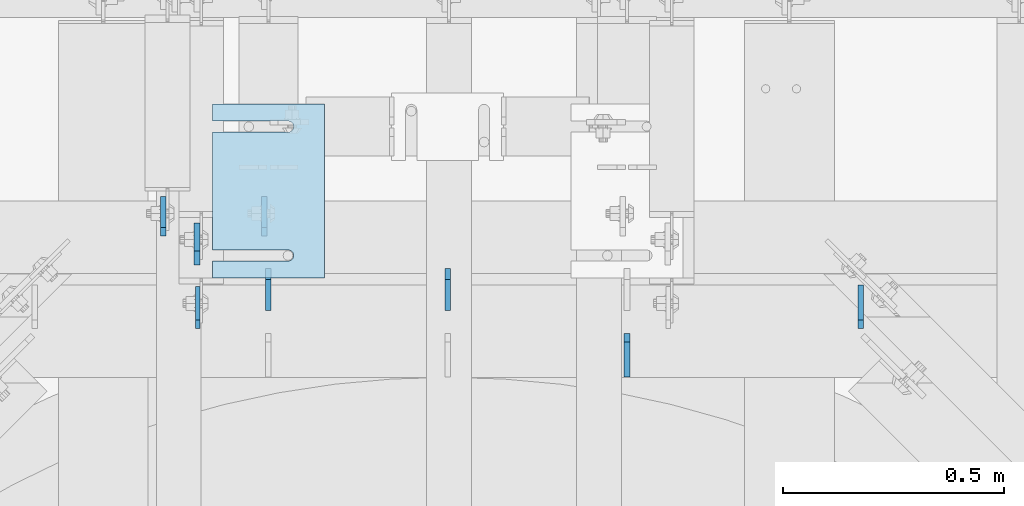
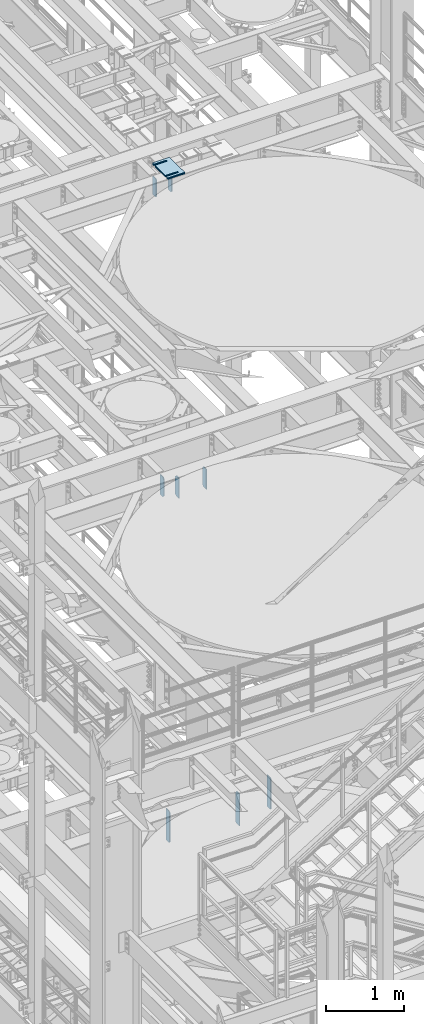
# One storey, part 1574 of 1876: 14 plates, 9 elements without a shape of their own.
"""IFC2X3 building model written with IfcOpenShell, lengths in millimetres."""

from ifc_helpers import new_model, si_unit, frame, origin_with_axes, place, context, subcontext, project, spatial, faceted_brep, material, type_object, element, aggregate, save


model = new_model("IFC2X3")

# Units and contexts
model_context = context("Model", 3, precision=1e-05, world=origin_with_axes())
body_context = subcontext(model_context, "Body", "Model", "MODEL_VIEW")
ifc_project = project(units=[si_unit("LENGTHUNIT", "METRE", prefix="MILLI"), si_unit("AREAUNIT", "SQUARE_METRE"), si_unit("VOLUMEUNIT", "CUBIC_METRE"), si_unit("MASSUNIT", "GRAM", prefix="KILO"), si_unit("TIMEUNIT", "SECOND"), si_unit("PLANEANGLEUNIT", "RADIAN"), si_unit("SOLIDANGLEUNIT", "STERADIAN"), si_unit("THERMODYNAMICTEMPERATUREUNIT", "DEGREE_CELSIUS"), si_unit("LUMINOUSINTENSITYUNIT", "LUMEN")], contexts=[model_context])

# Site, building, storey
site_placement = place(None, origin_with_axes())
site = spatial("IfcSite", under=ifc_project, at=site_placement, CompositionType="ELEMENT")
building_placement = place(site_placement, origin_with_axes())
building = spatial("IfcBuilding", under=site, at=building_placement, Name="Undefined", CompositionType="ELEMENT")
storey_placement = place(building_placement, origin_with_axes())
storey = spatial("IfcBuildingStorey", under=building, at=storey_placement, Name="Undefined", CompositionType="ELEMENT", Elevation=0.0)

# Assembly, plates
assembly_1_placement = place(storey_placement, origin_with_axes())
assembly_1 = element("IfcElementAssembly", 1, at=assembly_1_placement, inside=storey, Name="BEAM", AssemblyPlace="NOTDEFINED", PredefinedType="RIGID_FRAME")
ifc_material = material(Name="STEEL/A36")
plate_type_1 = type_object("IfcPlateType", PredefinedType="NOTDEFINED")
plate_1_placement = place(assembly_1_placement, frame((3852.86200008392, 704.254688, 7635.875), z_axis=(0.0, 0.0, 1.0), x_axis=(0.0, 1.0, 0.0)))
plate_1 = element("IfcPlate", 2, at=plate_1_placement, type_object=plate_type_1, material=ifc_material, Name="PLATE", context=body_context, shape_type="Brep", body=[
    faceted_brep([(0.0, -4.76249999999982, 19.0499992370605), (0.0, -4.76249999999982, 481.012500762939), (0.0, 4.76249999999982, 481.012500762939), (0.0, 4.76249999999982, 19.0499992370605), (19.0499992370605, -4.76249999999982, 500.0625), (19.0499992370605, 4.76249999999982, 500.0625), (95.25, -4.76249999999982, 500.0625), (95.25, 4.76249999999982, 500.0625), (95.25, -4.76249999999982, 0.0), (95.25, 4.76249999999982, 0.0), (19.0499992370605, -4.76249999999982, 0.0), (19.0499992370605, 4.76249999999982, 0.0)], [[[0, 1, 2, 3]], [[1, 4, 5, 2]], [[4, 6, 7, 5]], [[6, 8, 9, 7]], [[8, 10, 11, 9]], [[10, 0, 3, 11]], [[5, 7, 9, 11, 3, 2]], [[10, 8, 6, 4, 1, 0]]]),
])
plate_type_2 = type_object("IfcPlateType", PredefinedType="NOTDEFINED")
plate_2_placement = place(assembly_1_placement, frame((4825.99999998806, 594.717188, 7634.2875), z_axis=(0.0, 0.0, 1.0), x_axis=(0.0, 1.0, 0.0)))
plate_2 = element("IfcPlate", 3, at=plate_2_placement, type_object=plate_type_2, material=ifc_material, Name="PLATE", context=body_context, shape_type="Brep", body=[
    faceted_brep([(0.0, -6.35000000000036, 0.0), (0.0, -6.34999999999991, 501.649993896484), (0.0, 6.34999999999991, 501.649993896484), (0.0, 6.35000000000036, 0.0), (79.3750038146973, -6.34999999999991, 501.649993896484), (79.3750038146973, 6.34999999999991, 501.649993896484), (98.4250030517578, -6.34999999999991, 476.249994277954), (98.4250030517578, 6.34999999999991, 476.249994277954), (98.4250030517578, -6.34999999999991, 19.0499992370605), (98.4250030517578, 6.34999999999991, 19.0499992370605), (79.3750038146973, -6.34999999999991, 0.0), (79.3750038146973, 6.34999999999991, 0.0)], [[[0, 1, 2, 3]], [[1, 4, 5, 2]], [[4, 6, 7, 5]], [[6, 8, 9, 7]], [[8, 10, 11, 9]], [[10, 0, 3, 11]], [[5, 7, 9, 11, 3, 2]], [[10, 8, 6, 4, 1, 0]]]),
])

assembly_2_placement = place(storey_placement, origin_with_axes())
assembly_2 = element("IfcElementAssembly", 4, at=assembly_2_placement, inside=storey, Name="BEAM", AssemblyPlace="NOTDEFINED", PredefinedType="RIGID_FRAME")
plate_type_3 = type_object("IfcPlateType", PredefinedType="NOTDEFINED")
plate_3_placement = place(assembly_2_placement, frame((4003.67517775661, 914.399999999455, 17681.575), z_axis=(0.0, 0.0, 1.0), x_axis=(0.0, 1.0, 0.0)))
plate_3 = element("IfcPlate", 5, at=plate_3_placement, type_object=plate_type_3, material=ifc_material, Name="PLATE", context=body_context, shape_type="Brep", body=[
    faceted_brep([(0.0, -6.35000000000196, 19.0499992370605), (0.0, -6.35000000000036, 271.462512969971), (0.0, 6.35000000000036, 271.462512969971), (0.0, 6.35000000000105, 19.0499992370605), (19.0499992370605, -6.35000000000036, 290.512512207031), (19.0499992370605, 6.35000000000036, 290.512512207031), (88.9000015258789, -6.35000000000036, 290.512512207031), (88.9000015258789, 6.35000000000036, 290.512512207031), (88.9000015258789, -6.34999999999991, 0.0), (88.9000015258789, 6.34999999999991, 0.0), (19.0499992370642, -6.35000000000105, 0.0), (19.0499992370633, 6.35000000000105, 0.0)], [[[0, 1, 2, 3]], [[1, 4, 5, 2]], [[4, 6, 7, 5]], [[6, 8, 9, 7]], [[8, 10, 11, 9]], [[10, 0, 3, 11]], [[5, 7, 9, 11, 3, 2]], [[10, 8, 6, 4, 1, 0]]]),
])
plate_4_placement = place(assembly_2_placement, frame((3775.07499990463, 914.399999999455, 17679.9875), z_axis=(0.0, 0.0, 1.0), x_axis=(0.0, 1.0, 0.0)))
plate_4 = element("IfcPlate", 6, at=plate_4_placement, type_object=plate_type_3, material=ifc_material, Name="PLATE", context=body_context, shape_type="Brep", body=[
    faceted_brep([(0.0, -6.35000000000196, 19.0499992370605), (9.09494701772928e-13, -6.34999999999832, 273.050006866455), (-2.72848410531878e-12, 6.34999999999923, 273.050006866455), (0.0, 6.35000000000105, 19.0499992370605), (19.0499992370578, -6.35000000000696, 292.100006103516), (19.049999237056, 6.3499999999915, 292.100006103516), (88.9000015258789, -6.35000000000036, 292.100006103516), (88.9000015258789, 6.35000000000036, 292.100006103516), (88.9000015258789, -6.34999999999991, 0.0), (88.9000015258789, 6.34999999999991, 0.0), (19.0499992370642, -6.35000000000105, 0.0), (19.0499992370633, 6.35000000000105, 0.0)], [[[0, 1, 2, 3]], [[1, 4, 5, 2]], [[4, 6, 7, 5]], [[6, 8, 9, 7]], [[8, 10, 11, 9]], [[10, 0, 3, 11]], [[5, 7, 9, 11, 3, 2]], [[10, 8, 6, 4, 1, 0]]]),
])
aggregate(assembly_2, [plate_3, plate_4])

assembly_3_placement = place(storey_placement, origin_with_axes())
assembly_3 = element("IfcElementAssembly", 7, at=assembly_3_placement, inside=storey, Name="BEAM", AssemblyPlace="NOTDEFINED", PredefinedType="RIGID_FRAME")
plate_type_4 = type_object("IfcPlateType", PredefinedType="NOTDEFINED")
plate_5_placement = place(assembly_3_placement, frame((4013.2, 745.33125, 12976.225), z_axis=(0.0, 0.0, 1.0), x_axis=(0.0, 1.0, 0.0)))
plate_5 = element("IfcPlate", 8, at=plate_5_placement, type_object=plate_type_4, material=ifc_material, Name="PLATE", context=body_context, shape_type="Brep", body=[
    faceted_brep([(0.0, -6.35000000000036, 0.0), (1.81898940354586e-12, -6.35000000000127, 317.5), (0.0, 6.35000000000036, 317.5), (0.0, 6.35000000000036, 0.0), (69.8500003814697, -6.34999999999991, 317.5), (69.8500003814697, 6.34999999999991, 317.5), (95.25, -6.34999999999991, 292.10000038147), (95.25, 6.34999999999991, 292.10000038147), (95.25, -6.34999999999991, 25.3999996185303), (95.25, 6.34999999999991, 25.3999996185303), (69.8500003814697, -6.34999999999991, 0.0), (69.8500003814697, 6.34999999999991, 0.0)], [[[0, 1, 2, 3]], [[1, 4, 5, 2]], [[4, 6, 7, 5]], [[6, 8, 9, 7]], [[8, 10, 11, 9]], [[10, 0, 3, 11]], [[5, 7, 9, 11, 3, 2]], [[10, 8, 6, 4, 1, 0]]]),
])
plate_6_placement = place(assembly_3_placement, frame((4419.6, 745.33125, 12976.225), z_axis=(0.0, 0.0, 1.0), x_axis=(0.0, 1.0, 0.0)))
plate_6 = element("IfcPlate", 9, at=plate_6_placement, type_object=plate_type_4, material=ifc_material, Name="PLATE", context=body_context, shape_type="Brep", body=[
    faceted_brep([(0.0, -6.35000000000036, 0.0), (1.81898940354586e-12, -6.35000000000127, 317.5), (0.0, 6.35000000000036, 317.5), (0.0, 6.35000000000036, 0.0), (69.8500003814697, -6.34999999999991, 317.5), (69.8500003814697, 6.34999999999991, 317.5), (95.25, -6.34999999999991, 292.10000038147), (95.25, 6.34999999999991, 292.10000038147), (95.25, -6.34999999999991, 25.3999996185303), (95.25, 6.34999999999991, 25.3999996185303), (69.8500003814697, -6.34999999999991, 0.0), (69.8500003814697, 6.34999999999991, 0.0)], [[[0, 1, 2, 3]], [[1, 4, 5, 2]], [[4, 6, 7, 5]], [[6, 8, 9, 7]], [[8, 10, 11, 9]], [[10, 0, 3, 11]], [[5, 7, 9, 11, 3, 2]], [[10, 8, 6, 4, 1, 0]]]),
])
plate_7_placement = place(assembly_3_placement, frame((3851.27499990463, 848.51875, 12977.8125), z_axis=(0.0, 0.0, 1.0), x_axis=(0.0, 1.0, 0.0)))
plate_7 = element("IfcPlate", 10, at=plate_7_placement, type_object=plate_type_4, material=ifc_material, Name="PLATE", context=body_context, shape_type="Brep", body=[
    faceted_brep([(0.0, -6.34999999999991, 31.75), (-1.81898940354586e-12, -6.34999999999991, 284.162506103516), (1.81898940354586e-12, 6.35000000000173, 284.162506103516), (0.0, 6.34999999999991, 31.75), (31.7499999999927, -6.34999999999991, 315.912506103516), (31.7499999999982, 6.35000000000309, 315.912506103516), (95.25, -6.35000000000036, 315.912506103516), (95.25, 6.35000000000036, 315.912506103516), (95.25, -6.35000000000036, 0.0), (95.25, 6.35000000000036, 0.0), (31.75, -6.34999999999991, 0.0), (31.75, 6.34999999999991, 0.0)], [[[0, 1, 2, 3]], [[1, 4, 5, 2]], [[4, 6, 7, 5]], [[6, 8, 9, 7]], [[8, 10, 11, 9]], [[10, 0, 3, 11]], [[5, 7, 9, 11, 3, 2]], [[10, 8, 6, 4, 1, 0]]]),
])
aggregate(assembly_3, [plate_5, plate_6, plate_7])

# Plate
plate_type_5 = type_object("IfcPlateType", PredefinedType="NOTDEFINED")
plate_8_placement = place(assembly_1_placement, frame((5355.59998036883, 704.254688, 7635.875), z_axis=(0.0, 0.0, 1.0), x_axis=(0.0, 1.0, 0.0)))
plate_8 = element("IfcPlate", 11, at=plate_8_placement, type_object=plate_type_5, material=ifc_material, Name="PLATE", context=body_context, shape_type="Brep", body=[
    faceted_brep([(0.0, -6.35000000000196, 19.0499992370605), (0.0, -6.34999999999991, 479.425006866455), (0.0, 6.34999999999991, 479.425006866455), (0.0, 6.35000000000105, 19.0499992370605), (19.0499992370605, -6.34999999999991, 498.475006103516), (19.0499992370605, 6.34999999999991, 498.475006103516), (99.21875, -6.34999999999991, 498.475006103516), (99.21875, 6.34999999999991, 498.475006103516), (99.21875, -6.34999999999991, 0.0), (99.21875, 6.34999999999991, 0.0), (19.0499992370642, -6.35000000000105, 0.0), (19.0499992370633, 6.35000000000105, 0.0)], [[[0, 1, 2, 3]], [[1, 4, 5, 2]], [[4, 6, 7, 5]], [[6, 8, 9, 7]], [[8, 10, 11, 9]], [[10, 0, 3, 11]], [[5, 7, 9, 11, 3, 2]], [[10, 8, 6, 4, 1, 0]]]),
])

aggregate(assembly_1, [plate_2, plate_8, plate_1])

# Assembly, plate
assembly_4_placement = place(storey_placement, origin_with_axes())
assembly_4 = element("IfcElementAssembly", 12, at=assembly_4_placement, inside=storey, Name="SHIM PLATE", AssemblyPlace="NOTDEFINED", PredefinedType="RIGID_FRAME")
plate_type_6 = type_object("IfcPlateType", PredefinedType="NOTDEFINED")
plate_9_placement = place(assembly_4_placement, frame((4140.19755067496, 819.151560067776, 18007.0115), z_axis=(-1.0, 0.0, 0.0), x_axis=(0.0, 1.0, 0.0)))
plate_9 = element("IfcPlate", 13, at=plate_9_placement, type_object=plate_type_6, material=ifc_material, Name="SHIM PLATE", context=body_context, shape_type="Brep", body=[
    faceted_brep([(38.0954210666328, -1.58750000000146, 253.999557495103), (38.0976431969724, -1.58750000000146, 82.6182312417654), (38.0976431969724, 1.58750000000146, 82.6182312417654), (38.0954210666328, 1.58750000000146, 253.999557495103), (39.7991131045027, -1.58750000000146, 76.2682279470096), (39.7991131045027, 1.58750000000146, 76.2682279470096), (44.4476316136985, -1.58750000000146, 71.6196994315187), (44.4476316136985, 1.58750000000146, 71.6196994315187), (50.7976312458977, -1.58750000000146, 69.9182158551362), (50.7976312458977, 1.58750000000146, 69.9182158551362), (57.1476337740625, -1.58750000000146, 71.6196886236189), (57.1476337740625, 1.58750000000146, 71.6196886236189), (61.7961601951824, -1.58750000000146, 76.2682092271793), (61.7961601951824, 1.58750000000146, 76.2682092271793), (63.497640910601, -1.58750000000146, 82.6182096259718), (63.497640910601, 1.58750000000146, 82.6182096259718), (63.4954187799489, -1.58750000000146, 253.999557267866), (63.4954187799489, 1.58750000000146, 253.999557495093), (9.09494701772928e-13, -1.58750000000146, 4.54747350886464e-13), (1.89071320164658e-05, -1.58750000000146, 253.999557495117), (1.89071320164658e-05, 1.58750000000146, 253.999557495117), (9.09494701772928e-13, 1.58750000000146, 4.54747350886464e-13), (393.698486328125, -1.58750000000146, -1.40062184073031e-10), (393.698486328125, 1.58750000000146, -1.40062184073031e-10), (393.698516845714, -1.58750000000146, 253.999557494967), (393.698516845714, 1.58750000000146, 253.999557494967), (355.593905292273, 1.58750000000146, 253.999557494981), (355.593905292273, -1.58750000000146, 253.999558194833), (355.596127251301, 1.58750000000146, 82.6182258117283), (355.596127251301, -1.58750000000146, 82.6182258117283), (353.894652887411, 1.58750000000146, 76.2682211679371), (353.894652887411, -1.58750000000146, 76.2682211679371), (349.246128913514, 1.58750000000146, 71.6196946431969), (349.246128913514, -1.58750000000146, 71.6196946431969), (342.896125203397, 1.58750000000146, 69.9182167947934), (342.896125203397, -1.58750000000146, 69.9182167947934), (336.546122348359, 1.58750000000146, 71.6196978343955), (336.546122348359, -1.58750000000146, 71.6196978343955), (331.897600710579, 1.58750000000146, 76.2682266952543), (331.897600710579, -1.58750000000146, 76.2682266952543), (330.196129537885, 1.58750000000146, 82.6182321941214), (330.196129537885, -1.58750000000146, 82.6182321941214), (330.193907578964, -1.58750000000146, 253.999557494991), (330.193907578964, 1.58750000000146, 253.999557494991)], [[[0, 1, 2, 3]], [[4, 5, 2, 1]], [[6, 7, 5, 4]], [[8, 9, 7, 6]], [[10, 11, 9, 8]], [[12, 13, 11, 10]], [[14, 15, 13, 12]], [[16, 17, 15, 14]], [[18, 19, 20, 21]], [[22, 18, 21, 23]], [[24, 22, 23, 25]], [[24, 25, 26, 27]], [[27, 26, 28, 29]], [[29, 28, 30, 31]], [[31, 30, 32, 33]], [[33, 32, 34, 35]], [[35, 34, 36, 37]], [[37, 36, 38, 39]], [[39, 38, 40, 41]], [[42, 41, 40, 43]], [[12, 10, 8, 6, 4, 1, 0, 19, 18, 22, 24, 27, 29, 31, 33, 35, 37, 39, 41, 42, 16, 14]], [[20, 19, 0, 3]], [[43, 40, 38, 36, 34, 32, 30, 28, 26, 25, 23, 21, 20, 3, 2, 5, 7, 9, 11, 13, 15, 17]], [[42, 43, 17, 16]]]),
])
aggregate(assembly_4, [plate_9])

assembly_5_placement = place(storey_placement, origin_with_axes())
assembly_5 = element("IfcElementAssembly", 14, at=assembly_5_placement, inside=storey, Name="SHIM PLATE", AssemblyPlace="NOTDEFINED", PredefinedType="RIGID_FRAME")
plate_10_placement = place(assembly_5_placement, frame((4140.19755067514, 819.151560067778, 18003.8365), z_axis=(-1.0, 0.0, 0.0), x_axis=(0.0, 1.0, 0.0)))
plate_10 = element("IfcPlate", 15, at=plate_10_placement, type_object=plate_type_6, material=ifc_material, Name="SHIM PLATE", context=body_context, shape_type="Brep", body=[
    faceted_brep([(38.0954210666328, -1.58750000000146, 253.999557495103), (38.0976431969724, -1.58750000000146, 82.6182312417654), (38.0976431969724, 1.58750000000146, 82.6182312417654), (38.0954210666328, 1.58750000000146, 253.999557495103), (39.7991131045027, -1.58750000000146, 76.2682279470096), (39.7991131045027, 1.58750000000146, 76.2682279470096), (44.4476316136985, -1.58750000000146, 71.6196994315187), (44.4476316136985, 1.58750000000146, 71.6196994315187), (50.7976312458977, -1.58750000000146, 69.9182158551362), (50.7976312458977, 1.58750000000146, 69.9182158551362), (57.1476337740625, -1.58750000000146, 71.6196886236189), (57.1476337740625, 1.58750000000146, 71.6196886236189), (61.7961601951824, -1.58750000000146, 76.2682092271793), (61.7961601951824, 1.58750000000146, 76.2682092271793), (63.497640910601, -1.58750000000146, 82.6182096259718), (63.497640910601, 1.58750000000146, 82.6182096259718), (63.4954187799489, -1.58750000000146, 253.999557267866), (63.4954187799489, 1.58750000000146, 253.999557495093), (9.09494701772928e-13, -1.58750000000146, 4.54747350886464e-13), (1.89071320164658e-05, -1.58750000000146, 253.999557495117), (1.89071320164658e-05, 1.58750000000146, 253.999557495117), (9.09494701772928e-13, 1.58750000000146, 4.54747350886464e-13), (393.698486328125, -1.58750000000146, -1.40062184073031e-10), (393.698486328125, 1.58750000000146, -1.40062184073031e-10), (393.698516845714, -1.58750000000146, 253.999557494967), (393.698516845714, 1.58750000000146, 253.999557494967), (355.593905292273, 1.58750000000146, 253.999557494981), (355.593905292273, -1.58750000000146, 253.999558194833), (355.596127251301, 1.58750000000146, 82.6182258117283), (355.596127251301, -1.58750000000146, 82.6182258117283), (353.894652887411, 1.58750000000146, 76.2682211679371), (353.894652887411, -1.58750000000146, 76.2682211679371), (349.246128913514, 1.58750000000146, 71.6196946431969), (349.246128913514, -1.58750000000146, 71.6196946431969), (342.896125203397, 1.58750000000146, 69.9182167947934), (342.896125203397, -1.58750000000146, 69.9182167947934), (336.546122348359, 1.58750000000146, 71.6196978343955), (336.546122348359, -1.58750000000146, 71.6196978343955), (331.897600710579, 1.58750000000146, 76.2682266952543), (331.897600710579, -1.58750000000146, 76.2682266952543), (330.196129537885, 1.58750000000146, 82.6182321941214), (330.196129537885, -1.58750000000146, 82.6182321941214), (330.193907578964, -1.58750000000146, 253.999557494991), (330.193907578964, 1.58750000000146, 253.999557494991)], [[[0, 1, 2, 3]], [[4, 5, 2, 1]], [[6, 7, 5, 4]], [[8, 9, 7, 6]], [[10, 11, 9, 8]], [[12, 13, 11, 10]], [[14, 15, 13, 12]], [[16, 17, 15, 14]], [[18, 19, 20, 21]], [[22, 18, 21, 23]], [[24, 22, 23, 25]], [[24, 25, 26, 27]], [[27, 26, 28, 29]], [[29, 28, 30, 31]], [[31, 30, 32, 33]], [[33, 32, 34, 35]], [[35, 34, 36, 37]], [[37, 36, 38, 39]], [[39, 38, 40, 41]], [[42, 41, 40, 43]], [[12, 10, 8, 6, 4, 1, 0, 19, 18, 22, 24, 27, 29, 31, 33, 35, 37, 39, 41, 42, 16, 14]], [[20, 19, 0, 3]], [[43, 40, 38, 36, 34, 32, 30, 28, 26, 25, 23, 21, 20, 3, 2, 5, 7, 9, 11, 13, 15, 17]], [[42, 43, 17, 16]]]),
])
aggregate(assembly_5, [plate_10])

assembly_6_placement = place(storey_placement, origin_with_axes())
assembly_6 = element("IfcElementAssembly", 16, at=assembly_6_placement, inside=storey, Name="SHIM PLATE", AssemblyPlace="NOTDEFINED", PredefinedType="RIGID_FRAME")
plate_type_7 = type_object("IfcPlateType", PredefinedType="NOTDEFINED")
plate_11_placement = place(assembly_6_placement, frame((4140.19755067479, 819.151560067774, 18009.3925), z_axis=(-1.0, 0.0, 0.0), x_axis=(0.0, 1.0, 0.0)))
plate_11 = element("IfcPlate", 17, at=plate_11_placement, type_object=plate_type_7, material=ifc_material, Name="SHIM PLATE", context=body_context, shape_type="Brep", body=[
    faceted_brep([(38.0954210666328, -0.793499999999767, 253.999557495103), (38.0976431969724, -0.793499999999767, 82.6182312417654), (38.0976431969724, 0.793499999999767, 82.6182312417654), (38.0954210666328, 0.793499999999767, 253.999557495103), (39.7991131045027, -0.793499999999767, 76.2682279470096), (39.7991131045027, 0.793499999999767, 76.2682279470096), (44.4476316136985, -0.793499999999767, 71.6196994315187), (44.4476316136985, 0.793499999999767, 71.6196994315187), (50.7976312458977, -0.793499999999767, 69.9182158551362), (50.7976312458977, 0.793499999999767, 69.9182158551362), (57.1476337740625, -0.793499999999767, 71.6196886236189), (57.1476337740625, 0.793499999999767, 71.6196886236189), (61.7961601951824, -0.793499999999767, 76.2682092271793), (61.7961601951824, 0.793499999999767, 76.2682092271793), (63.497640910601, -0.793499999999767, 82.6182096259718), (63.497640910601, 0.793499999999767, 82.6182096259718), (63.4954187799489, -0.793499999999767, 253.999557267866), (63.4954187799489, 0.793499999999767, 253.999557495093), (9.09494701772928e-13, -0.793499999999767, 0.0), (1.89070156011439e-05, -0.793499999999767, 253.999557495117), (1.89070156011439e-05, 0.793499999999767, 253.999557495117), (9.09494701772928e-13, 0.793499999999767, 0.0), (393.698486328125, -0.793499999999767, -1.39152689371258e-10), (393.698486328125, 0.793499999999767, -1.39152689371258e-10), (393.698516845714, -0.793499999999767, 253.999557494967), (393.698516845714, 0.793499999999767, 253.999557494967), (355.593905292273, 0.793499999999767, 253.999557494981), (355.593905292273, -0.793499999999767, 253.999558194833), (355.596127251301, 0.793499999999767, 82.6182258117283), (355.596127251301, -0.793499999999767, 82.6182258117283), (353.894652887411, 0.793499999999767, 76.2682211679371), (353.894652887411, -0.793499999999767, 76.2682211679371), (349.246128913514, 0.793499999999767, 71.6196946431969), (349.246128913514, -0.793499999999767, 71.6196946431969), (342.896125203397, 0.793499999999767, 69.9182167947934), (342.896125203397, -0.793499999999767, 69.9182167947934), (336.546122348359, 0.793499999999767, 71.6196978343955), (336.546122348359, -0.793499999999767, 71.6196978343955), (331.897600710579, 0.793499999999767, 76.2682266952543), (331.897600710579, -0.793499999999767, 76.2682266952543), (330.196129537885, 0.793499999999767, 82.6182321941214), (330.196129537885, -0.793499999999767, 82.6182321941214), (330.193907578964, -0.793499999999767, 253.999557494991), (330.193907578964, 0.793499999999767, 253.999557494991)], [[[0, 1, 2, 3]], [[4, 5, 2, 1]], [[6, 7, 5, 4]], [[8, 9, 7, 6]], [[10, 11, 9, 8]], [[12, 13, 11, 10]], [[14, 15, 13, 12]], [[16, 17, 15, 14]], [[18, 19, 20, 21]], [[22, 18, 21, 23]], [[24, 22, 23, 25]], [[24, 25, 26, 27]], [[27, 26, 28, 29]], [[29, 28, 30, 31]], [[31, 30, 32, 33]], [[33, 32, 34, 35]], [[35, 34, 36, 37]], [[37, 36, 38, 39]], [[39, 38, 40, 41]], [[42, 41, 40, 43]], [[12, 10, 8, 6, 4, 1, 0, 19, 18, 22, 24, 27, 29, 31, 33, 35, 37, 39, 41, 42, 16, 14]], [[20, 19, 0, 3]], [[43, 40, 38, 36, 34, 32, 30, 28, 26, 25, 23, 21, 20, 3, 2, 5, 7, 9, 11, 13, 15, 17]], [[42, 43, 17, 16]]]),
])
aggregate(assembly_6, [plate_11])

assembly_7_placement = place(storey_placement, origin_with_axes())
assembly_7 = element("IfcElementAssembly", 18, at=assembly_7_placement, inside=storey, Name="SHIM PLATE", AssemblyPlace="NOTDEFINED", PredefinedType="RIGID_FRAME")
plate_type_8 = type_object("IfcPlateType", PredefinedType="NOTDEFINED")
plate_12_placement = place(assembly_7_placement, frame((4140.19755067532, 819.151560067779, 17999.868), z_axis=(-1.0, 0.0, 0.0), x_axis=(0.0, 1.0, 0.0)))
plate_12 = element("IfcPlate", 19, at=plate_12_placement, type_object=plate_type_8, material=ifc_material, Name="SHIM PLATE", context=body_context, shape_type="Brep", body=[
    faceted_brep([(38.0954210666329, -2.38100000000122, 253.999557495103), (38.0976431969724, -2.38100000000122, 82.6182312417654), (38.0976431969724, 2.38100000000122, 82.6182312417654), (38.0954210666329, 2.38100000000122, 253.999557495103), (39.7991131045027, -2.38100000000122, 76.2682279470096), (39.7991131045027, 2.38100000000122, 76.2682279470096), (44.4476316136985, -2.38100000000122, 71.6196994315187), (44.4476316136985, 2.38100000000122, 71.6196994315187), (50.7976312458977, -2.38100000000122, 69.9182158551362), (50.7976312458977, 2.38100000000122, 69.9182158551362), (57.1476337740625, -2.38100000000122, 71.6196886236189), (57.1476337740625, 2.38100000000122, 71.6196886236189), (61.7961601951824, -2.38100000000122, 76.2682092271793), (61.7961601951824, 2.38100000000122, 76.2682092271793), (63.497640910601, -2.38100000000122, 82.6182096259718), (63.497640910601, 2.38100000000122, 82.6182096259718), (63.4954187799489, -2.38100000000122, 253.999557267866), (63.4954187799489, 2.38100000000122, 253.999557495093), (0.0, -2.38100000000122, 4.54747350886464e-13), (1.89072484317876e-05, -2.38100000000122, 253.999557495117), (1.89072484317876e-05, 2.38100000000122, 253.999557495117), (0.0, 2.38100000000122, 4.54747350886464e-13), (393.698486328125, -2.38100000000122, -1.40971678774804e-10), (393.698486328125, 2.38100000000122, -1.40971678774804e-10), (393.698516845714, -2.38100000000122, 253.999557494967), (393.698516845714, 2.38100000000122, 253.999557494967), (355.593905292273, 2.38100000000122, 253.999557494981), (355.593905292273, -2.38100000000122, 253.999558194833), (355.596127251301, 2.38100000000122, 82.6182258117283), (355.596127251301, -2.38100000000122, 82.6182258117283), (353.894652887411, 2.38100000000122, 76.2682211679371), (353.894652887411, -2.38100000000122, 76.2682211679371), (349.246128913514, 2.38100000000122, 71.6196946431969), (349.246128913514, -2.38100000000122, 71.6196946431969), (342.896125203397, 2.38100000000122, 69.9182167947934), (342.896125203397, -2.38100000000122, 69.9182167947934), (336.546122348359, 2.38100000000122, 71.6196978343955), (336.546122348359, -2.38100000000122, 71.6196978343955), (331.897600710579, 2.38100000000122, 76.2682266952543), (331.897600710579, -2.38100000000122, 76.2682266952543), (330.196129537885, 2.38100000000122, 82.6182321941214), (330.196129537885, -2.38100000000122, 82.6182321941214), (330.193907578964, -2.38100000000122, 253.999557494991), (330.193907578964, 2.38100000000122, 253.999557494991)], [[[0, 1, 2, 3]], [[4, 5, 2, 1]], [[6, 7, 5, 4]], [[8, 9, 7, 6]], [[10, 11, 9, 8]], [[12, 13, 11, 10]], [[14, 15, 13, 12]], [[16, 17, 15, 14]], [[18, 19, 20, 21]], [[22, 18, 21, 23]], [[24, 22, 23, 25]], [[24, 25, 26, 27]], [[27, 26, 28, 29]], [[29, 28, 30, 31]], [[31, 30, 32, 33]], [[33, 32, 34, 35]], [[35, 34, 36, 37]], [[37, 36, 38, 39]], [[39, 38, 40, 41]], [[42, 41, 40, 43]], [[12, 10, 8, 6, 4, 1, 0, 19, 18, 22, 24, 27, 29, 31, 33, 35, 37, 39, 41, 42, 16, 14]], [[20, 19, 0, 3]], [[43, 40, 38, 36, 34, 32, 30, 28, 26, 25, 23, 21, 20, 3, 2, 5, 7, 9, 11, 13, 15, 17]], [[42, 43, 17, 16]]]),
])
aggregate(assembly_7, [plate_12])

assembly_8_placement = place(storey_placement, origin_with_axes())
assembly_8 = element("IfcElementAssembly", 20, at=assembly_8_placement, inside=storey, Name="SHIM PLATE", AssemblyPlace="NOTDEFINED", PredefinedType="RIGID_FRAME")
plate_13_placement = place(assembly_8_placement, frame((4140.1975506755, 819.151560067779, 17995.106), z_axis=(-1.0, 0.0, 0.0), x_axis=(0.0, 1.0, 0.0)))
plate_13 = element("IfcPlate", 21, at=plate_13_placement, type_object=plate_type_8, material=ifc_material, Name="SHIM PLATE", context=body_context, shape_type="Brep", body=[
    faceted_brep([(38.0954210666329, -2.38100000000122, 253.999557495103), (38.0976431969724, -2.38100000000122, 82.6182312417654), (38.0976431969724, 2.38100000000122, 82.6182312417654), (38.0954210666329, 2.38100000000122, 253.999557495103), (39.7991131045027, -2.38100000000122, 76.2682279470096), (39.7991131045027, 2.38100000000122, 76.2682279470096), (44.4476316136985, -2.38100000000122, 71.6196994315187), (44.4476316136985, 2.38100000000122, 71.6196994315187), (50.7976312458977, -2.38100000000122, 69.9182158551362), (50.7976312458977, 2.38100000000122, 69.9182158551362), (57.1476337740625, -2.38100000000122, 71.6196886236189), (57.1476337740625, 2.38100000000122, 71.6196886236189), (61.7961601951824, -2.38100000000122, 76.2682092271793), (61.7961601951824, 2.38100000000122, 76.2682092271793), (63.497640910601, -2.38100000000122, 82.6182096259718), (63.497640910601, 2.38100000000122, 82.6182096259718), (63.4954187799489, -2.38100000000122, 253.999557267866), (63.4954187799489, 2.38100000000122, 253.999557495093), (0.0, -2.38100000000122, 4.54747350886464e-13), (1.89072484317876e-05, -2.38100000000122, 253.999557495117), (1.89072484317876e-05, 2.38100000000122, 253.999557495117), (0.0, 2.38100000000122, 4.54747350886464e-13), (393.698486328125, -2.38100000000122, -1.40971678774804e-10), (393.698486328125, 2.38100000000122, -1.40971678774804e-10), (393.698516845714, -2.38100000000122, 253.999557494967), (393.698516845714, 2.38100000000122, 253.999557494967), (355.593905292273, 2.38100000000122, 253.999557494981), (355.593905292273, -2.38100000000122, 253.999558194833), (355.596127251301, 2.38100000000122, 82.6182258117283), (355.596127251301, -2.38100000000122, 82.6182258117283), (353.894652887411, 2.38100000000122, 76.2682211679371), (353.894652887411, -2.38100000000122, 76.2682211679371), (349.246128913514, 2.38100000000122, 71.6196946431969), (349.246128913514, -2.38100000000122, 71.6196946431969), (342.896125203397, 2.38100000000122, 69.9182167947934), (342.896125203397, -2.38100000000122, 69.9182167947934), (336.546122348359, 2.38100000000122, 71.6196978343955), (336.546122348359, -2.38100000000122, 71.6196978343955), (331.897600710579, 2.38100000000122, 76.2682266952543), (331.897600710579, -2.38100000000122, 76.2682266952543), (330.196129537885, 2.38100000000122, 82.6182321941214), (330.196129537885, -2.38100000000122, 82.6182321941214), (330.193907578964, -2.38100000000122, 253.999557494991), (330.193907578964, 2.38100000000122, 253.999557494991)], [[[0, 1, 2, 3]], [[4, 5, 2, 1]], [[6, 7, 5, 4]], [[8, 9, 7, 6]], [[10, 11, 9, 8]], [[12, 13, 11, 10]], [[14, 15, 13, 12]], [[16, 17, 15, 14]], [[18, 19, 20, 21]], [[22, 18, 21, 23]], [[24, 22, 23, 25]], [[24, 25, 26, 27]], [[27, 26, 28, 29]], [[29, 28, 30, 31]], [[31, 30, 32, 33]], [[33, 32, 34, 35]], [[35, 34, 36, 37]], [[37, 36, 38, 39]], [[39, 38, 40, 41]], [[42, 41, 40, 43]], [[12, 10, 8, 6, 4, 1, 0, 19, 18, 22, 24, 27, 29, 31, 33, 35, 37, 39, 41, 42, 16, 14]], [[20, 19, 0, 3]], [[43, 40, 38, 36, 34, 32, 30, 28, 26, 25, 23, 21, 20, 3, 2, 5, 7, 9, 11, 13, 15, 17]], [[42, 43, 17, 16]]]),
])
aggregate(assembly_8, [plate_13])

assembly_9_placement = place(storey_placement, origin_with_axes())
assembly_9 = element("IfcElementAssembly", 22, at=assembly_9_placement, inside=storey, Name="SHIM PLATE", AssemblyPlace="NOTDEFINED", PredefinedType="RIGID_FRAME")
plate_type_9 = type_object("IfcPlateType", PredefinedType="NOTDEFINED")
plate_14_placement = place(assembly_9_placement, frame((4140.19755067568, 819.151560067777, 17987.9625), z_axis=(-1.0, 0.0, 0.0), x_axis=(0.0, 1.0, 0.0)))
plate_14 = element("IfcPlate", 23, at=plate_14_placement, type_object=plate_type_9, material=ifc_material, Name="SHIM PLATE", context=body_context, shape_type="Brep", body=[
    faceted_brep([(38.0954210666328, -4.76250000000073, 253.999557495103), (38.0976431969724, -4.76250000000073, 82.6182312417654), (38.0976431969724, 4.76250000000073, 82.6182312417654), (38.0954210666328, 4.76250000000073, 253.999557495103), (39.7991131045027, -4.76250000000073, 76.2682279470096), (39.7991131045027, 4.76250000000073, 76.2682279470096), (44.4476316136985, -4.76250000000073, 71.6196994315187), (44.4476316136985, 4.76250000000073, 71.6196994315187), (50.7976312458977, -4.76250000000073, 69.9182158551362), (50.7976312458977, 4.76250000000073, 69.9182158551362), (57.1476337740625, -4.76250000000073, 71.6196886236189), (57.1476337740625, 4.76250000000073, 71.6196886236189), (61.7961601951824, -4.76250000000073, 76.2682092271793), (61.7961601951824, 4.76250000000073, 76.2682092271793), (63.497640910601, -4.76250000000073, 82.6182096259718), (63.497640910601, 4.76250000000073, 82.6182096259718), (63.4954187799489, -4.76250000000073, 253.999557267866), (63.4954187799489, 4.76250000000073, 253.999557495093), (0.0, -4.76249999999982, 0.0), (1.89073648471094e-05, -4.76250000000073, 253.999557495117), (1.89073648471094e-05, 4.76250000000073, 253.999557495117), (0.0, 4.76249999999982, 0.0), (393.698486328125, -4.76250000000073, -1.41881173476577e-10), (393.698486328125, 4.76250000000073, -1.41881173476577e-10), (393.698516845714, -4.76250000000073, 253.999557494967), (393.698516845714, 4.76250000000073, 253.999557494967), (355.593905292273, 4.76250000000073, 253.999557494981), (355.593905292273, -4.76250000000073, 253.999558194833), (355.596127251301, 4.76250000000073, 82.6182258117283), (355.596127251301, -4.76250000000073, 82.6182258117283), (353.894652887411, 4.76250000000073, 76.2682211679371), (353.894652887411, -4.76250000000073, 76.2682211679371), (349.246128913514, 4.76250000000073, 71.6196946431969), (349.246128913514, -4.76250000000073, 71.6196946431969), (342.896125203397, 4.76250000000073, 69.9182167947934), (342.896125203397, -4.76250000000073, 69.9182167947934), (336.546122348359, 4.76250000000073, 71.6196978343955), (336.546122348359, -4.76250000000073, 71.6196978343955), (331.897600710579, 4.76250000000073, 76.2682266952543), (331.897600710579, -4.76250000000073, 76.2682266952543), (330.196129537885, 4.76250000000073, 82.6182321941214), (330.196129537885, -4.76250000000073, 82.6182321941214), (330.193907578964, -4.76250000000073, 253.999557494991), (330.193907578964, 4.76250000000073, 253.999557494991)], [[[0, 1, 2, 3]], [[4, 5, 2, 1]], [[6, 7, 5, 4]], [[8, 9, 7, 6]], [[10, 11, 9, 8]], [[12, 13, 11, 10]], [[14, 15, 13, 12]], [[16, 17, 15, 14]], [[18, 19, 20, 21]], [[22, 18, 21, 23]], [[24, 22, 23, 25]], [[24, 25, 26, 27]], [[27, 26, 28, 29]], [[29, 28, 30, 31]], [[31, 30, 32, 33]], [[33, 32, 34, 35]], [[35, 34, 36, 37]], [[37, 36, 38, 39]], [[39, 38, 40, 41]], [[42, 41, 40, 43]], [[12, 10, 8, 6, 4, 1, 0, 19, 18, 22, 24, 27, 29, 31, 33, 35, 37, 39, 41, 42, 16, 14]], [[20, 19, 0, 3]], [[43, 40, 38, 36, 34, 32, 30, 28, 26, 25, 23, 21, 20, 3, 2, 5, 7, 9, 11, 13, 15, 17]], [[42, 43, 17, 16]]]),
])
aggregate(assembly_9, [plate_14])

save(model, "model.ifc")
